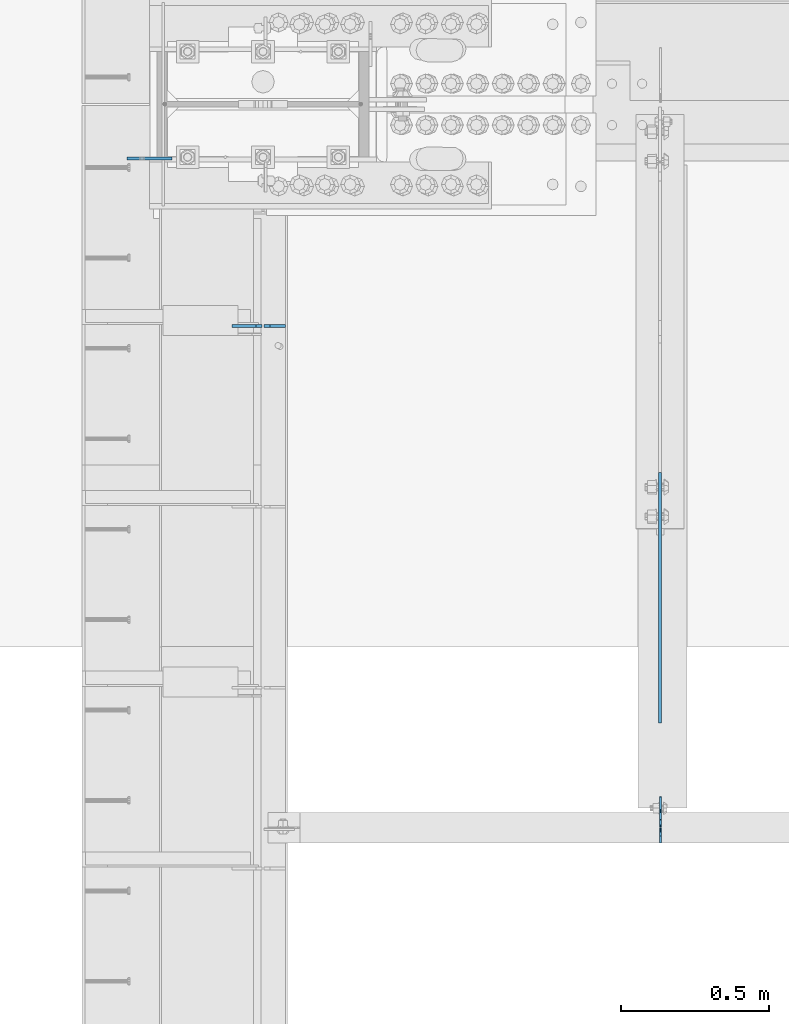
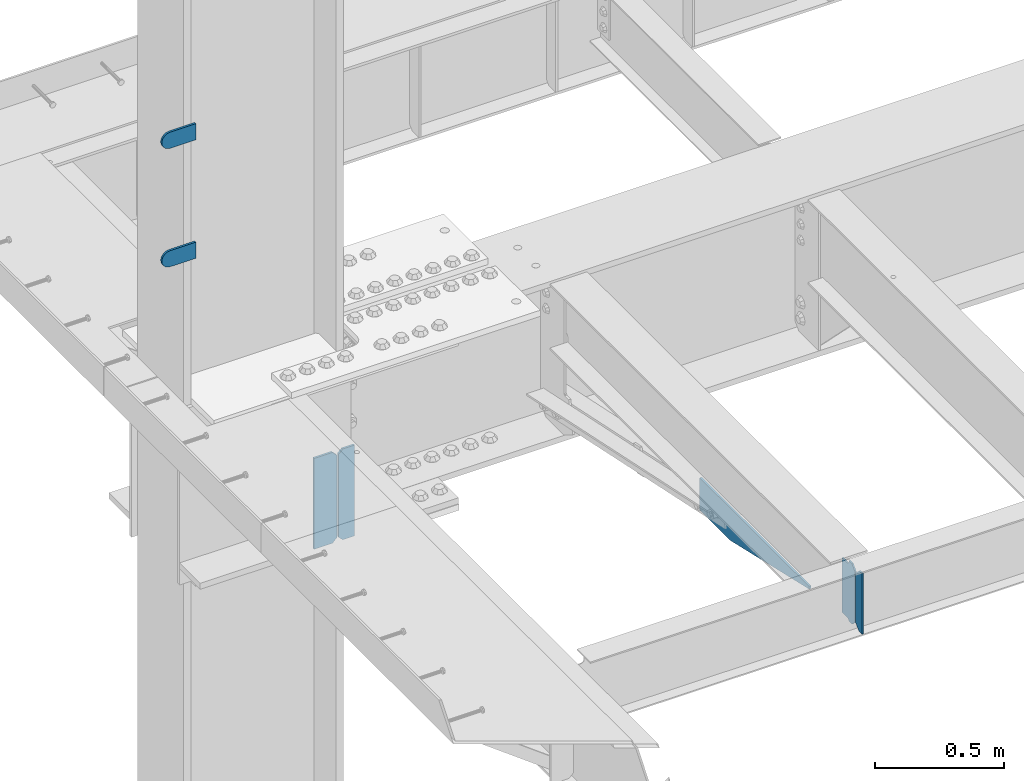
# One storey, part 1594 of 1763: 7 plates, 4 elements without a shape of their own.
"""IFC2X3 building model written with IfcOpenShell, lengths in millimetres."""

from ifc_helpers import new_model, si_unit, frame, origin_with_axes, place, context, subcontext, project, spatial, faceted_brep, material, type_object, element, aggregate, save


model = new_model("IFC2X3")

# Units and contexts
model_context = context("Model", 3, precision=1e-05, world=origin_with_axes())
body_context = subcontext(model_context, "Body", "Model", "MODEL_VIEW")
ifc_project = project(units=[si_unit("LENGTHUNIT", "METRE", prefix="MILLI"), si_unit("AREAUNIT", "SQUARE_METRE"), si_unit("VOLUMEUNIT", "CUBIC_METRE"), si_unit("MASSUNIT", "GRAM", prefix="KILO"), si_unit("TIMEUNIT", "SECOND"), si_unit("PLANEANGLEUNIT", "RADIAN"), si_unit("SOLIDANGLEUNIT", "STERADIAN"), si_unit("THERMODYNAMICTEMPERATUREUNIT", "DEGREE_CELSIUS"), si_unit("LUMINOUSINTENSITYUNIT", "LUMEN")], contexts=[model_context])

# Site, building, storey
site_placement = place(None, origin_with_axes())
site = spatial("IfcSite", under=ifc_project, at=site_placement, CompositionType="ELEMENT")
building_placement = place(site_placement, origin_with_axes())
building = spatial("IfcBuilding", under=site, at=building_placement, Name="Undefined", CompositionType="ELEMENT")
storey_placement = place(building_placement, origin_with_axes())
storey = spatial("IfcBuildingStorey", under=building, at=storey_placement, Name="Undefined", CompositionType="ELEMENT", Elevation=0.0)

# Assembly, plates
assembly_1_placement = place(storey_placement, origin_with_axes())
assembly_1 = element("IfcElementAssembly", 1, at=assembly_1_placement, inside=storey, Name="COLUMN", AssemblyPlace="NOTDEFINED", PredefinedType="RIGID_FRAME")
ifc_material = material(Name="STEEL/A36")
plate_type_1 = type_object("IfcPlateType", PredefinedType="NOTDEFINED")
plate_1_placement = place(assembly_1_placement, frame((-87681.8247736983, 51938.2375, 6489.69999847412), z_axis=(0.0, 0.0, -1.0), x_axis=(-1.0, 0.0, 0.0)))
plate_1 = element("IfcPlate", 2, at=plate_1_placement, type_object=plate_type_1, material=ifc_material, Name="PLATE", context=body_context, shape_type="Brep", body=[
    faceted_brep([(0.0, -4.76249999999982, 0.0), (0.0, -4.76250000000073, 76.1999969482422), (0.0, 4.76250000000073, 76.1999969482422), (0.0, 4.76249999999982, 0.0), (114.299995422363, -4.76250000000073, 76.1999969482422), (114.299995422363, 4.76250000000073, 76.1999969482422), (126.073542436527, -4.76250000000073, 74.3352502937696), (126.073542436527, 4.76250000000073, 74.3352502937696), (136.694612637817, -4.76250000000073, 68.923544725345), (136.694612637817, 4.76250000000073, 68.923544725345), (145.123541673587, -4.76250000000073, 60.4946156895749), (145.123541673587, 4.76250000000073, 60.4946156895749), (150.535247242013, -4.76250000000073, 49.8735454882844), (150.535247242013, 4.76250000000073, 49.8735454882844), (152.399993896484, -4.76250000000073, 38.0999984741211), (152.399993896484, 4.76250000000073, 38.0999984741211), (150.535247242013, -4.76250000000073, 26.3264514599578), (150.535247242013, 4.76250000000073, 26.3264514599578), (145.123541673587, -4.76250000000073, 15.7053812586673), (145.123541673587, 4.76250000000073, 15.7053812586673), (136.694612637817, -4.76250000000073, 7.27645222289721), (136.694612637817, 4.76250000000073, 7.27645222289721), (126.073542436527, -4.76250000000073, 1.86474665447258), (126.073542436527, 4.76250000000073, 1.86474665447258), (114.299995422363, -4.76250000000073, 0.0), (114.299995422363, 4.76250000000073, 0.0)], [[[0, 1, 2, 3]], [[1, 4, 5, 2]], [[4, 6, 7, 5]], [[6, 8, 9, 7]], [[8, 10, 11, 9]], [[10, 12, 13, 11]], [[12, 14, 15, 13]], [[14, 16, 17, 15]], [[16, 18, 19, 17]], [[18, 20, 21, 19]], [[20, 22, 23, 21]], [[22, 24, 25, 23]], [[24, 0, 3, 25]], [[5, 7, 9, 11, 13, 15, 17, 19, 21, 23, 25, 3, 2]], [[24, 22, 20, 18, 16, 14, 12, 10, 8, 6, 4, 1, 0]]]),
])
plate_2_placement = place(assembly_1_placement, frame((-87681.8247736983, 51938.2375, 5930.89999847412), z_axis=(0.0, 0.0, -1.0), x_axis=(-1.0, 0.0, 0.0)))
plate_2 = element("IfcPlate", 3, at=plate_2_placement, type_object=plate_type_1, material=ifc_material, Name="PLATE", context=body_context, shape_type="Brep", body=[
    faceted_brep([(0.0, -4.76249999999982, 0.0), (0.0, -4.76250000000073, 76.1999969482422), (0.0, 4.76250000000073, 76.1999969482422), (0.0, 4.76249999999982, 0.0), (114.299995422363, -4.76250000000073, 76.1999969482422), (114.299995422363, 4.76250000000073, 76.1999969482422), (126.073542436527, -4.76250000000073, 74.3352502937696), (126.073542436527, 4.76250000000073, 74.3352502937696), (136.694612637817, -4.76250000000073, 68.923544725345), (136.694612637817, 4.76250000000073, 68.923544725345), (145.123541673587, -4.76250000000073, 60.4946156895749), (145.123541673587, 4.76250000000073, 60.4946156895749), (150.535247242013, -4.76250000000073, 49.8735454882844), (150.535247242013, 4.76250000000073, 49.8735454882844), (152.399993896484, -4.76250000000073, 38.0999984741211), (152.399993896484, 4.76250000000073, 38.0999984741211), (150.535247242013, -4.76250000000073, 26.3264514599578), (150.535247242013, 4.76250000000073, 26.3264514599578), (145.123541673587, -4.76250000000073, 15.7053812586673), (145.123541673587, 4.76250000000073, 15.7053812586673), (136.694612637817, -4.76250000000073, 7.27645222289721), (136.694612637817, 4.76250000000073, 7.27645222289721), (126.073542436527, -4.76250000000073, 1.86474665447258), (126.073542436527, 4.76250000000073, 1.86474665447258), (114.299995422363, -4.76250000000073, 0.0), (114.299995422363, 4.76250000000073, 0.0)], [[[0, 1, 2, 3]], [[1, 4, 5, 2]], [[4, 6, 7, 5]], [[6, 8, 9, 7]], [[8, 10, 11, 9]], [[10, 12, 13, 11]], [[12, 14, 15, 13]], [[14, 16, 17, 15]], [[16, 18, 19, 17]], [[18, 20, 21, 19]], [[20, 22, 23, 21]], [[22, 24, 25, 23]], [[24, 0, 3, 25]], [[5, 7, 9, 11, 13, 15, 17, 19, 21, 23, 25, 3, 2]], [[24, 22, 20, 18, 16, 14, 12, 10, 8, 6, 4, 1, 0]]]),
])
aggregate(assembly_1, [plate_1, plate_2])

# Assembly, plate
assembly_2_placement = place(storey_placement, origin_with_axes())
assembly_2 = element("IfcElementAssembly", 4, at=assembly_2_placement, inside=storey, Name="BEAM", AssemblyPlace="NOTDEFINED", PredefinedType="RIGID_FRAME")
plate_type_2 = type_object("IfcPlateType", PredefinedType="NOTDEFINED")
plate_3_placement = place(assembly_2_placement, frame((-86037.1747736984, 50880.5595338104, 4883.15), z_axis=(0.0, -1.0, 0.0), x_axis=(0.0, 0.0, -1.0)))
plate_3 = element("IfcPlate", 5, at=plate_3_placement, type_object=plate_type_2, material=ifc_material, Name="PLATE", context=body_context, shape_type="Brep", body=[
    faceted_brep([(0.0, -4.76249999999982, 0.0), (0.0, -4.76249999999709, 844.603210449219), (0.0, 4.76249999999709, 844.603210449219), (0.0, 4.76249999999982, 0.0), (12.6999998092651, -4.76249999999709, 844.603210449219), (12.6999998092651, 4.76249999999709, 844.603210449219), (152.399993896484, -4.76249999999709, 235.00325012207), (152.399993896484, 4.76249999999709, 235.00325012207), (152.400009155272, -4.76249999948777, 5.45696821063757e-12), (152.400009155273, 4.76250000051368, 3.63797880709171e-12)], [[[0, 1, 2, 3]], [[1, 4, 5, 2]], [[4, 6, 7, 5]], [[6, 8, 9, 7]], [[8, 0, 3, 9]], [[5, 7, 9, 3, 2]], [[8, 6, 4, 1, 0]]]),
])
aggregate(assembly_2, [plate_3])

# Assembly, plates
assembly_3_placement = place(storey_placement, origin_with_axes())
assembly_3 = element("IfcElementAssembly", 6, at=assembly_3_placement, inside=storey, Name="BEAM", AssemblyPlace="NOTDEFINED", PredefinedType="RIGID_FRAME")
plate_type_3 = type_object("IfcPlateType", PredefinedType="NOTDEFINED")
plate_4_placement = place(assembly_3_placement, frame((-87299.2372736983, 51373.88125, 4752.975), z_axis=(0.0, 0.0, 1.0), x_axis=(-1.0, 0.0, 0.0)))
plate_4 = element("IfcPlate", 7, at=plate_4_placement, type_object=plate_type_3, material=ifc_material, Name="PLATE", context=body_context, shape_type="Brep", body=[
    faceted_brep([(0.0, -4.76249999999982, 0.0), (0.0, -4.76249999999709, 428.625), (0.0, 4.76249999999709, 428.625), (0.0, 4.76249999999982, 0.0), (53.1812477111816, -4.76249999999709, 428.625), (53.1812477111816, 4.76249999999709, 428.625), (72.2312469482422, -4.76249999999709, 409.575000762939), (72.2312469482422, 4.76249999999709, 409.575000762939), (72.2312469482422, -4.76249999999709, 19.0499992370605), (72.2312469482422, 4.76249999999709, 19.0499992370605), (53.1812477111816, -4.76249999999709, 0.0), (53.1812477111816, 4.76249999999709, 0.0)], [[[0, 1, 2, 3]], [[1, 4, 5, 2]], [[4, 6, 7, 5]], [[6, 8, 9, 7]], [[8, 10, 11, 9]], [[10, 0, 3, 11]], [[5, 7, 9, 11, 3, 2]], [[10, 8, 6, 4, 1, 0]]]),
])
plate_type_4 = type_object("IfcPlateType", PredefinedType="NOTDEFINED")
plate_5_placement = place(assembly_3_placement, frame((-87379.4060236983, 51373.88125, 4752.975), z_axis=(0.0, 0.0, 1.0), x_axis=(-1.0, 0.0, 0.0)))
plate_5 = element("IfcPlate", 8, at=plate_5_placement, type_object=plate_type_4, material=ifc_material, Name="PLATE", context=body_context, shape_type="Brep", body=[
    faceted_brep([(6.96272763889283e-08, -4.76249999999709, 19.0499992370605), (0.0, -4.76249999999709, 409.575000762939), (0.0, 4.76249999999709, 409.575000762939), (6.96454662829638e-08, 4.76249999999709, 19.0499992370605), (19.0499992370605, -4.76249999999709, 428.625), (19.0499992370605, 4.76249999999709, 428.625), (100.806251525879, -4.76249999999709, 428.625), (100.806251525879, 4.76249999999709, 428.625), (100.806251525879, -4.76249999999709, 0.0), (100.806251525879, 4.76249999999709, 0.0), (19.0499992370533, -4.76249999996799, -2.09183781407773e-11), (19.0499992370678, 4.76250000003347, -2.09183781407773e-11)], [[[0, 1, 2, 3]], [[1, 4, 5, 2]], [[4, 6, 7, 5]], [[6, 8, 9, 7]], [[8, 10, 11, 9]], [[10, 0, 3, 11]], [[5, 7, 9, 11, 3, 2]], [[10, 8, 6, 4, 1, 0]]]),
])
aggregate(assembly_3, [plate_4, plate_5])

assembly_4_placement = place(storey_placement, origin_with_axes())
assembly_4 = element("IfcElementAssembly", 9, at=assembly_4_placement, inside=storey, Name="BEAM", AssemblyPlace="NOTDEFINED", PredefinedType="RIGID_FRAME")
plate_type_5 = type_object("IfcPlateType", PredefinedType="NOTDEFINED")
plate_6_placement = place(assembly_4_placement, frame((-86035.587273746, 49684.78125, 4900.6125), z_axis=(0.0, 0.0, 1.0), x_axis=(0.0, 1.0, 0.0)))
plate_6 = element("IfcPlate", 10, at=plate_6_placement, type_object=plate_type_5, material=ifc_material, Name="PLATE", context=body_context, shape_type="Brep", body=[
    faceted_brep([(48.7345236062902, -3.17500000000291, 0.0), (48.7345236062902, 3.17500000000291, 0.0), (49.3854800386544, 3.17500000000291, 3.27257877585271), (49.3854800386544, -3.17500000000291, 3.27257877585271), (52.1384942519726, 3.17500000000291, 7.39275539271512), (52.1384942519726, -3.17500000000291, 7.39275539271512), (56.2586711318072, 3.17500000000291, 10.1457692124714), (56.2586711318072, -3.17500000000291, 10.1457692124714), (61.1187510223899, 3.17500000000291, 11.1124987868779), (61.1187510223899, -3.17500000000291, 11.1124987868779), (101.599998474121, -3.17500000000291, 11.1124949200548), (101.599998474121, 3.17500000000291, 11.1124949200548), (25.3999996184939, -3.17499999996653, 1.2732925824821e-11), (0.0, -3.17499999987194, 25.4000000001051), (0.0, 3.17500000014843, 25.4000000001197), (25.3999996185303, 3.17499995230901, 0.0), (0.0, -3.17500000000291, 261.937494277954), (0.0, 3.17500000000291, 261.937494277954), (25.3999996185303, -3.17500000000291, 287.337493896484), (25.3999996185303, 3.17500000000291, 287.337493896484), (48.4187500000044, -3.17500000000291, 287.337493896484), (48.4187500000044, 3.17500000000291, 287.337493896484), (48.4187500000044, -3.17500000000291, 280.987500572204), (48.4187500000044, 3.17500000000291, 280.987500572204), (49.3854799225956, -3.17500000000291, 276.127421054159), (49.3854799225956, 3.17500000000291, 276.127421054159), (52.1384938230694, -3.17500000000291, 272.007244586005), (52.1384938230694, 3.17500000000291, 272.007244586005), (56.2586702912231, -3.17500000000291, 269.254230685527), (56.2586702912231, 3.17500000000291, 269.254230685527), (61.1187498092695, -3.17500000000291, 268.287500762939), (61.1187498092695, 3.17500000000291, 268.287500762939), (101.599998474121, -3.17500000000291, 268.287500762939), (101.599998474121, 3.17500000000291, 268.287500762939)], [[[0, 1, 2, 3]], [[3, 2, 4, 5]], [[5, 4, 6, 7]], [[7, 6, 8, 9]], [[10, 9, 8, 11]], [[12, 13, 14, 15]], [[13, 16, 17, 14]], [[16, 18, 19, 17]], [[19, 18, 20, 21]], [[20, 22, 23, 21]], [[24, 25, 23, 22]], [[26, 27, 25, 24]], [[28, 29, 27, 26]], [[30, 31, 29, 28]], [[32, 33, 31, 30]], [[33, 32, 10, 11]], [[6, 4, 2, 1, 15, 14, 17, 19, 21, 23, 25, 27, 29, 31, 33, 11, 8]], [[12, 15, 1, 0]], [[32, 30, 28, 26, 24, 22, 20, 18, 16, 13, 12, 0, 3, 5, 7, 9, 10]]]),
])
plate_type_6 = type_object("IfcPlateType", PredefinedType="NOTDEFINED")
plate_7_placement = place(assembly_4_placement, frame((-86035.587273746, 49680.01875, 4900.6125), z_axis=(0.0, 0.0, 1.0), x_axis=(0.0, -1.0, 0.0)))
plate_7 = element("IfcPlate", 11, at=plate_7_placement, type_object=plate_type_6, material=ifc_material, Name="PLATE", context=body_context, shape_type="Brep", body=[
    faceted_brep([(0.0, -3.17499999987194, 25.4000000001051), (0.0, -3.17500000000291, 260.35000038147), (0.0, 3.17500000000291, 260.35000038147), (0.0, 3.17500000014843, 25.4000000001197), (25.3999996185303, -3.17500000000291, 285.75), (25.3999996185303, 3.17500000000291, 285.75), (48.4187507629395, -3.17500000000291, 285.75), (48.4187507629395, 3.17500000000291, 285.75), (48.4187507629395, -3.17500000000291, 0.0), (48.4187507629395, 3.17500000000291, 0.0), (25.3999996184939, -3.17499999996653, 1.2732925824821e-11), (25.3999996185303, 3.17499995230901, 0.0)], [[[0, 1, 2, 3]], [[1, 4, 5, 2]], [[4, 6, 7, 5]], [[6, 8, 9, 7]], [[8, 10, 11, 9]], [[10, 0, 3, 11]], [[5, 7, 9, 11, 3, 2]], [[10, 8, 6, 4, 1, 0]]]),
])
aggregate(assembly_4, [plate_7, plate_6])

save(model, "model.ifc")
